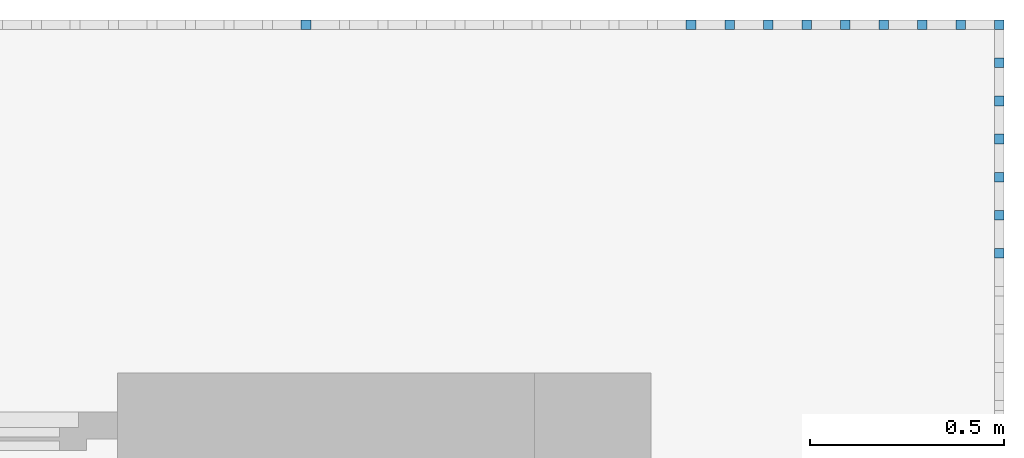
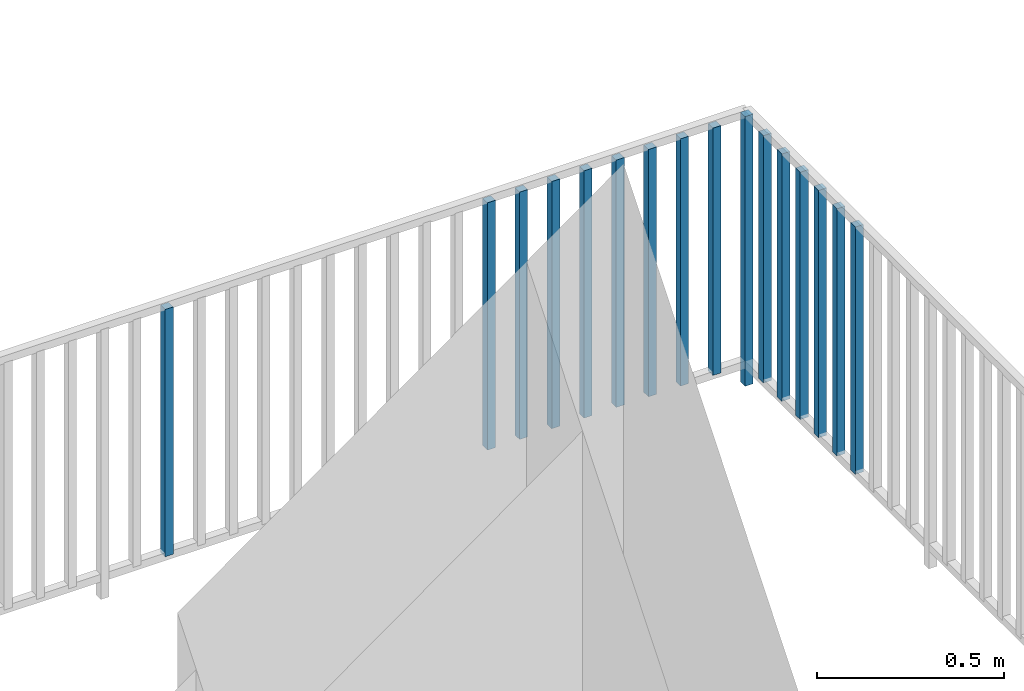
# One storey, part 48 of 48: 17 building element parts, 1 element without a shape of its own.
"""IFC4 building model written with IfcOpenShell, lengths in metres."""

import ifcopenshell
import ifcopenshell.guid

model = None  # the IFC model being written
_history = None  # IfcOwnerHistory: only IFC2X3 demands one
_inside = {}  # id of a spatial element -> (the spatial element, [elements in it])
_under = {}  # id of a project, library or spatial element -> (it, [spatial elements below it])
_declared = {}  # id of a project -> (the project, [libraries it declares])
_typed = {}  # id of a type object -> (the type object, [elements of that type])
_made_of = {}  # id of a material, layer set ... -> (it, [elements and type objects made of it])


def new_model(schema):
    """Start an empty IFC model of exactly this schema.

    Asked for "IFC4X3", IfcOpenShell would pick the latest addendum, in which some entities
    have other attributes; the version numbers below select the first issue.
    IFC2X3 requires an IfcOwnerHistory on every rooted entity: one is made here for all.
    """
    global model, _history
    if schema == "IFC4X3":
        model = ifcopenshell.file(schema_version=(4, 3, 0, 0))
    else:
        model = ifcopenshell.file(schema=schema)
    _inside.clear()
    _under.clear()
    _declared.clear()
    _typed.clear()
    _made_of.clear()
    _history = None
    if model.schema == "IFC2X3":
        org = make("IfcOrganization", Name="unknown")
        user = make(
            "IfcPersonAndOrganization",
            ThePerson=make("IfcPerson", FamilyName="unknown"),
            TheOrganization=org,
        )
        app = make(
            "IfcApplication",
            ApplicationDeveloper=org,
            Version="unknown",
            ApplicationFullName="unknown",
            ApplicationIdentifier="unknown",
        )
        _history = make(
            "IfcOwnerHistory",
            OwningUser=user,
            OwningApplication=app,
            ChangeAction="ADDED",
            CreationDate=0,
        )
    return model


def make(cls, **values):
    """One entity of the class cls with the attributes given. An attribute that is None is left unset."""
    return model.create_entity(
        cls, **{name: value for name, value in values.items() if value is not None}
    )


def entity(cls, *values):
    """Any entity or typed value of the class cls, its attributes in the order of the schema. None: left unset."""
    e = model.create_entity(cls)
    for i, value in enumerate(values):
        if value is not None:
            e[i] = value
    return e


def rooted(cls, **values):
    """An entity with a GlobalId (a new one), such as an element, a storey or a relation."""
    return make(cls, GlobalId=ifcopenshell.guid.new(), OwnerHistory=_history, **values)


def si_unit(unit_type, name, prefix=None):
    """IfcSIUnit, for example si_unit("LENGTHUNIT", "METRE", prefix="MILLI")."""
    return make("IfcSIUnit", UnitType=unit_type, Prefix=prefix, Name=name)


def converted_unit(unit_type, name, factor, base, dimensions=None, offset=None):
    """IfcConversionBasedUnit, such as the inch: factor (a typed value) times the base unit."""
    return make(
        "IfcConversionBasedUnit"
        if offset is None
        else "IfcConversionBasedUnitWithOffset",
        ConversionOffset=offset,
        Dimensions=None
        if dimensions is None
        else entity("IfcDimensionalExponents", *dimensions),
        UnitType=unit_type,
        Name=name,
        ConversionFactor=make(
            "IfcMeasureWithUnit", ValueComponent=factor, UnitComponent=base
        ),
    )


def derived_unit(unit_type, elements):
    """IfcDerivedUnit: a product of units, each with its exponent."""
    return make(
        "IfcDerivedUnit",
        Elements=[
            make("IfcDerivedUnitElement", Unit=unit, Exponent=power)
            for unit, power in elements
        ],
        UnitType=unit_type,
    )


def assignment(units):
    """IfcUnitAssignment: the units of a project."""
    return None if units is None else make("IfcUnitAssignment", Units=units)


def point(xyz):
    """IfcCartesianPoint."""
    return None if xyz is None else make("IfcCartesianPoint", Coordinates=xyz)


def direction(xyz):
    """IfcDirection."""
    return None if xyz is None else make("IfcDirection", DirectionRatios=xyz)


def frame(location, z_axis=None, x_axis=None):
    """IfcAxis2Placement3D, a coordinate frame: its origin and axes. An axis left out is left unset."""
    return make(
        "IfcAxis2Placement3D",
        Location=point(location),
        Axis=direction(z_axis),
        RefDirection=direction(x_axis),
    )


def origin_with_axes():
    """The frame at (0, 0, 0) with the z axis (0, 0, 1) and the x axis (1, 0, 0) written out."""
    return frame((0.0, 0.0, 0.0), z_axis=(0.0, 0.0, 1.0), x_axis=(1.0, 0.0, 0.0))


def place(relative_to, where):
    """IfcLocalPlacement: puts the frame where relative to a parent placement (None: the world)."""
    return make(
        "IfcLocalPlacement", PlacementRelTo=relative_to, RelativePlacement=where
    )


def context(
    kind, dimensions, precision=None, world=None, true_north=None, identifier=None
):
    """IfcGeometricRepresentationContext, for example the 3D "Model" context."""
    return make(
        "IfcGeometricRepresentationContext",
        ContextIdentifier=identifier,
        ContextType=kind,
        CoordinateSpaceDimension=dimensions,
        Precision=precision,
        WorldCoordinateSystem=world,
        TrueNorth=true_north,
    )


def subcontext(parent, identifier, kind, view, scale=None):
    """IfcGeometricRepresentationSubContext, for example "Body" below "Model"."""
    return make(
        "IfcGeometricRepresentationSubContext",
        ContextIdentifier=identifier,
        ContextType=kind,
        ParentContext=parent,
        TargetScale=scale,
        TargetView=view,
    )


def project(units=None, contexts=None):
    """IfcProject with its units and contexts."""
    return rooted(
        "IfcProject",
        Name="project",
        RepresentationContexts=contexts,
        UnitsInContext=assignment(units),
    )


def spatial(cls, under=None, at=None, **own):
    """A site, building, storey or space (cls), placed at a placement, below another one or the project."""
    s = rooted(cls, ObjectPlacement=at, **own)
    if under is not None:
        _under.setdefault(under.id(), (under, []))[1].append(s)
    return s


def point_list(points):
    """IfcCartesianPointList2D or 3D."""
    cls = (
        "IfcCartesianPointList2D" if len(points[0]) == 2 else "IfcCartesianPointList3D"
    )
    return make(cls, CoordList=points)


def polygons(points, faces, closed=None, point_numbers=None):
    """IfcPolygonalFaceSet: a face is its outer loop, then its inner loops; points numbered from 1."""
    made = []
    for loops in faces:
        if len(loops) == 1:
            made.append(make("IfcIndexedPolygonalFace", CoordIndex=loops[0]))
        else:
            made.append(
                make(
                    "IfcIndexedPolygonalFaceWithVoids",
                    CoordIndex=loops[0],
                    InnerCoordIndices=loops[1:],
                )
            )
    return make(
        "IfcPolygonalFaceSet",
        Coordinates=point_list(points),
        Closed=closed,
        Faces=made,
        PnIndex=point_numbers,
    )


def shape(context_of_items, identifier, shape_type, items):
    """IfcShapeRepresentation: the items that make up one representation, for example the "Body"."""
    return make(
        "IfcShapeRepresentation",
        ContextOfItems=context_of_items,
        RepresentationIdentifier=identifier,
        RepresentationType=shape_type,
        Items=items,
    )


def material(Name=None, Category=None):
    """IfcMaterial."""
    return make("IfcMaterial", Name=Name, Category=Category)


def made_of(thing, what):
    """Note that an element or type object is made of a material, layer set ...; save() writes the relation."""
    if what is not None:
        _made_of.setdefault(what.id(), (what, []))[1].append(thing)
    return thing


def type_object(cls, material=None, **own):
    """A type object (cls), such as IfcWallType, which elements share."""
    return made_of(rooted(cls, **own), material)


def element(
    cls,
    number,
    at=None,
    inside=None,
    cuts=None,
    type_object=None,
    material=None,
    context=None,
    identifier="Body",
    shape_type=None,
    held_by="IfcProductDefinitionShape",
    body=None,
    shapes=None,
    **own,
):
    """One element of the class cls, such as IfcWall. Its Tag is "e" and its number.

    at: its placement. inside: the storey or other place that contains it. cuts: it is an
    opening in that element (IfcRelVoidsElement). A single representation is given by context,
    identifier, shape_type and body (its items); several are given by shapes. held_by: the class
    of the entity that holds the representations. save() writes the other relations.
    """
    e = rooted(cls, Tag="e%d" % number, ObjectPlacement=at, **own)
    if body is not None:
        shapes = [shape(context, identifier, shape_type, body)]
    if shapes is not None:
        e.Representation = make(held_by, Representations=shapes)
    if inside is not None:
        _inside.setdefault(inside.id(), (inside, []))[1].append(e)
    if cuts is not None:
        rooted(
            "IfcRelVoidsElement", RelatingBuildingElement=cuts, RelatedOpeningElement=e
        )
    if type_object is not None:
        _typed.setdefault(type_object.id(), (type_object, []))[1].append(e)
    return made_of(e, material)


def aggregate(whole, parts):
    """IfcRelAggregates: a whole, such as a stair, and the parts it consists of."""
    return rooted("IfcRelAggregates", RelatingObject=whole, RelatedObjects=parts)


def save(model, path):
    """Write the relations noted so far, then the file.

    IfcRelAggregates (storeys below a building ...), IfcRelContainedInSpatialStructure (elements
    in a storey), IfcRelDefinesByType, IfcRelAssociatesMaterial and IfcRelDeclares: one each for
    every whole, place, type object, material and project.
    """
    for whole, parts in _under.values():
        aggregate(whole, parts)
    for where, things in _inside.values():
        rooted(
            "IfcRelContainedInSpatialStructure",
            RelatedElements=things,
            RelatingStructure=where,
        )
    for kind, things in _typed.values():
        rooted("IfcRelDefinesByType", RelatedObjects=things, RelatingType=kind)
    for what, things in _made_of.values():
        rooted("IfcRelAssociatesMaterial", RelatedObjects=things, RelatingMaterial=what)
    for by, libraries in _declared.values():
        rooted("IfcRelDeclares", RelatingContext=by, RelatedDefinitions=libraries)
    model.write(path)


model = new_model("IFC4")

# Units and contexts
model_context = context("Model", 3, precision=1e-05, world=origin_with_axes(), true_north=direction((0.0, 1.0)))
body_context = subcontext(model_context, "Body", "Model", "MODEL_VIEW")
ifc_project = project(units=[si_unit("LENGTHUNIT", "METRE"), si_unit("AREAUNIT", "SQUARE_METRE"), si_unit("VOLUMEUNIT", "CUBIC_METRE"), converted_unit("PLANEANGLEUNIT", "DEGREE", entity("IfcPlaneAngleMeasure", 0.0174532925199), si_unit("PLANEANGLEUNIT", "RADIAN"), dimensions=[0, 0, 0, 0, 0, 0, 0]), converted_unit("TIMEUNIT", "Year", entity("IfcTimeMeasure", 31556926.0), si_unit("TIMEUNIT", "SECOND"), dimensions=[0, 0, 1, 0, 0, 0, 0]), si_unit("MASSUNIT", "GRAM", prefix="KILO"), si_unit("THERMODYNAMICTEMPERATUREUNIT", "DEGREE_CELSIUS"), si_unit("LUMINOUSINTENSITYUNIT", "LUMEN"), si_unit("ENERGYUNIT", "JOULE", prefix="MEGA"), derived_unit("THERMALCONDUCTANCEUNIT", [(si_unit("POWERUNIT", "WATT"), 1), (si_unit("LENGTHUNIT", "METRE"), -1), (si_unit("THERMODYNAMICTEMPERATUREUNIT", "KELVIN"), -1)]), derived_unit("SPECIFICHEATCAPACITYUNIT", [(si_unit("ENERGYUNIT", "JOULE"), 1), (si_unit("MASSUNIT", "GRAM", prefix="KILO"), -1), (si_unit("THERMODYNAMICTEMPERATUREUNIT", "KELVIN"), -1)]), derived_unit("MASSDENSITYUNIT", [(si_unit("MASSUNIT", "GRAM", prefix="KILO"), 1), (si_unit("VOLUMEUNIT", "CUBIC_METRE"), -1)])], contexts=[model_context])

# Site, building, storey
site_placement = place(None, origin_with_axes())
site = spatial("IfcSite", under=ifc_project, at=site_placement, CompositionType="ELEMENT")
building_placement = place(site_placement, origin_with_axes())
building = spatial("IfcBuilding", under=site, at=building_placement, CompositionType="ELEMENT")
storey_placement = place(building_placement, frame((0.0, 0.0, 3.4), z_axis=(0.0, 0.0, 1.0), x_axis=(1.0, 0.0, 0.0)))
storey = spatial("IfcBuildingStorey", under=building, at=storey_placement, Name="1. Geschoss", CompositionType="ELEMENT", Elevation=3.4)

# Railing, building element parts
railing_type = type_object("IfcRailingType", PredefinedType="NOTDEFINED")
railing_placement = place(storey_placement, frame((10.2378006196, 9.82118776896, 0.0), z_axis=(0.0, 0.0, 1.0), x_axis=(1.0, 0.0, 0.0)))
railing = element("IfcRailing", 1, at=railing_placement, inside=storey, type_object=railing_type, PredefinedType="NOTDEFINED")
ifc_material = material()
building_element_part_1_placement = place(railing_placement, origin_with_axes())
building_element_part_1 = element("IfcBuildingElementPart", 2, at=building_element_part_1_placement, material=ifc_material, PredefinedType="NOTDEFINED", context=body_context, shape_type="Tessellation", body=[
    polygons([(-0.0125, 0.0125, 0.0), (-0.0125, -0.0125, 0.0), (-0.0125, -0.0125, 0.88), (-0.0125, 0.0125, 0.88), (0.0125, 0.0125, 0.0), (0.0125, -0.0125, 0.0), (0.0125, -0.0125, 0.88), (0.0125, 0.0125, 0.88)], [[[1, 2, 3, 4]], [[1, 5, 6, 2]], [[2, 6, 7, 3]], [[4, 3, 7, 8]], [[5, 1, 4, 8]], [[6, 5, 8, 7]]], closed=True),
])
building_element_part_2_placement = place(railing_placement, origin_with_axes())
building_element_part_2 = element("IfcBuildingElementPart", 3, at=building_element_part_2_placement, material=ifc_material, PredefinedType="NOTDEFINED", context=body_context, shape_type="Tessellation", body=[
    polygons([(0.0125, 0.0125, 0.0), (-0.0125, 0.0125, 0.0), (-0.0125, 0.0125, 0.88), (0.0125, 0.0125, 0.88), (0.0125, -0.0125, 0.0), (-0.0125, -0.0125, 0.0), (-0.0125, -0.0125, 0.88), (0.0125, -0.0125, 0.88)], [[[1, 2, 3, 4]], [[1, 5, 6, 2]], [[2, 6, 7, 3]], [[4, 3, 7, 8]], [[5, 1, 4, 8]], [[6, 5, 8, 7]]], closed=True),
])
building_element_part_3_placement = place(railing_placement, origin_with_axes())
building_element_part_3 = element("IfcBuildingElementPart", 4, at=building_element_part_3_placement, material=ifc_material, PredefinedType="NOTDEFINED", context=body_context, shape_type="Tessellation", body=[
    polygons([(-0.11197826087, 0.0125, 0.07), (-0.11197826087, -0.0125, 0.07), (-0.11197826087, -0.0125, 0.8775), (-0.11197826087, 0.0125, 0.8775), (-0.0869782608696, 0.0125, 0.07), (-0.0869782608696, -0.0125, 0.07), (-0.0869782608696, -0.0125, 0.8775), (-0.0869782608696, 0.0125, 0.8775)], [[[1, 2, 3, 4]], [[1, 5, 6, 2]], [[2, 6, 7, 3]], [[4, 3, 7, 8]], [[5, 1, 4, 8]], [[6, 5, 8, 7]]], closed=True),
])
building_element_part_4_placement = place(railing_placement, origin_with_axes())
building_element_part_4 = element("IfcBuildingElementPart", 5, at=building_element_part_4_placement, material=ifc_material, PredefinedType="NOTDEFINED", context=body_context, shape_type="Tessellation", body=[
    polygons([(-0.211456521739, 0.0125, 0.07), (-0.211456521739, -0.0125, 0.07), (-0.211456521739, -0.0125, 0.8775), (-0.211456521739, 0.0125, 0.8775), (-0.186456521739, 0.0125, 0.07), (-0.186456521739, -0.0125, 0.07), (-0.186456521739, -0.0125, 0.8775), (-0.186456521739, 0.0125, 0.8775)], [[[1, 2, 3, 4]], [[1, 5, 6, 2]], [[2, 6, 7, 3]], [[4, 3, 7, 8]], [[5, 1, 4, 8]], [[6, 5, 8, 7]]], closed=True),
])
building_element_part_5_placement = place(railing_placement, origin_with_axes())
building_element_part_5 = element("IfcBuildingElementPart", 6, at=building_element_part_5_placement, material=ifc_material, PredefinedType="NOTDEFINED", context=body_context, shape_type="Tessellation", body=[
    polygons([(-0.310934782609, 0.0125, 0.07), (-0.310934782609, -0.0125, 0.07), (-0.310934782609, -0.0125, 0.8775), (-0.310934782609, 0.0125, 0.8775), (-0.285934782609, 0.0125, 0.07), (-0.285934782609, -0.0125, 0.07), (-0.285934782609, -0.0125, 0.8775), (-0.285934782609, 0.0125, 0.8775)], [[[1, 2, 3, 4]], [[1, 5, 6, 2]], [[2, 6, 7, 3]], [[4, 3, 7, 8]], [[5, 1, 4, 8]], [[6, 5, 8, 7]]], closed=True),
])
building_element_part_6_placement = place(railing_placement, origin_with_axes())
building_element_part_6 = element("IfcBuildingElementPart", 7, at=building_element_part_6_placement, material=ifc_material, PredefinedType="NOTDEFINED", context=body_context, shape_type="Tessellation", body=[
    polygons([(-0.410413043478, 0.0125, 0.07), (-0.410413043478, -0.0125, 0.07), (-0.410413043478, -0.0125, 0.8775), (-0.410413043478, 0.0125, 0.8775), (-0.385413043478, 0.0125, 0.07), (-0.385413043478, -0.0125, 0.07), (-0.385413043478, -0.0125, 0.8775), (-0.385413043478, 0.0125, 0.8775)], [[[1, 2, 3, 4]], [[1, 5, 6, 2]], [[2, 6, 7, 3]], [[4, 3, 7, 8]], [[5, 1, 4, 8]], [[6, 5, 8, 7]]], closed=True),
])
building_element_part_7_placement = place(railing_placement, origin_with_axes())
building_element_part_7 = element("IfcBuildingElementPart", 8, at=building_element_part_7_placement, material=ifc_material, PredefinedType="NOTDEFINED", context=body_context, shape_type="Tessellation", body=[
    polygons([(-0.509891304348, 0.0125, 0.07), (-0.509891304348, -0.0125, 0.07), (-0.509891304348, -0.0125, 0.8775), (-0.509891304348, 0.0125, 0.8775), (-0.484891304348, 0.0125, 0.07), (-0.484891304348, -0.0125, 0.07), (-0.484891304348, -0.0125, 0.8775), (-0.484891304348, 0.0125, 0.8775)], [[[1, 2, 3, 4]], [[1, 5, 6, 2]], [[2, 6, 7, 3]], [[4, 3, 7, 8]], [[5, 1, 4, 8]], [[6, 5, 8, 7]]], closed=True),
])
building_element_part_8_placement = place(railing_placement, origin_with_axes())
building_element_part_8 = element("IfcBuildingElementPart", 9, at=building_element_part_8_placement, material=ifc_material, PredefinedType="NOTDEFINED", context=body_context, shape_type="Tessellation", body=[
    polygons([(-0.609369565217, 0.0125, 0.07), (-0.609369565217, -0.0125, 0.07), (-0.609369565217, -0.0125, 0.8775), (-0.609369565217, 0.0125, 0.8775), (-0.584369565217, 0.0125, 0.07), (-0.584369565217, -0.0125, 0.07), (-0.584369565217, -0.0125, 0.8775), (-0.584369565217, 0.0125, 0.8775)], [[[1, 2, 3, 4]], [[1, 5, 6, 2]], [[2, 6, 7, 3]], [[4, 3, 7, 8]], [[5, 1, 4, 8]], [[6, 5, 8, 7]]], closed=True),
])
building_element_part_9_placement = place(railing_placement, origin_with_axes())
building_element_part_9 = element("IfcBuildingElementPart", 10, at=building_element_part_9_placement, material=ifc_material, PredefinedType="NOTDEFINED", context=body_context, shape_type="Tessellation", body=[
    polygons([(-0.708847826087, 0.0125, 0.07), (-0.708847826087, -0.0125, 0.07), (-0.708847826087, -0.0125, 0.8775), (-0.708847826087, 0.0125, 0.8775), (-0.683847826087, 0.0125, 0.07), (-0.683847826087, -0.0125, 0.07), (-0.683847826087, -0.0125, 0.8775), (-0.683847826087, 0.0125, 0.8775)], [[[1, 2, 3, 4]], [[1, 5, 6, 2]], [[2, 6, 7, 3]], [[4, 3, 7, 8]], [[5, 1, 4, 8]], [[6, 5, 8, 7]]], closed=True),
])
building_element_part_10_placement = place(railing_placement, origin_with_axes())
building_element_part_10 = element("IfcBuildingElementPart", 11, at=building_element_part_10_placement, material=ifc_material, PredefinedType="NOTDEFINED", context=body_context, shape_type="Tessellation", body=[
    polygons([(-0.808326086957, 0.0125, 0.07), (-0.808326086957, -0.0125, 0.07), (-0.808326086957, -0.0125, 0.8775), (-0.808326086957, 0.0125, 0.8775), (-0.783326086957, 0.0125, 0.07), (-0.783326086957, -0.0125, 0.07), (-0.783326086957, -0.0125, 0.8775), (-0.783326086957, 0.0125, 0.8775)], [[[1, 2, 3, 4]], [[1, 5, 6, 2]], [[2, 6, 7, 3]], [[4, 3, 7, 8]], [[5, 1, 4, 8]], [[6, 5, 8, 7]]], closed=True),
])
building_element_part_11_placement = place(railing_placement, origin_with_axes())
building_element_part_11 = element("IfcBuildingElementPart", 12, at=building_element_part_11_placement, material=ifc_material, PredefinedType="NOTDEFINED", context=body_context, shape_type="Tessellation", body=[
    polygons([(-1.80310869565, 0.0125, 0.07), (-1.80310869565, -0.0125, 0.07), (-1.80310869565, -0.0125, 0.8775), (-1.80310869565, 0.0125, 0.8775), (-1.77810869565, 0.0125, 0.07), (-1.77810869565, -0.0125, 0.07), (-1.77810869565, -0.0125, 0.8775), (-1.77810869565, 0.0125, 0.8775)], [[[1, 2, 3, 4]], [[1, 5, 6, 2]], [[2, 6, 7, 3]], [[4, 3, 7, 8]], [[5, 1, 4, 8]], [[6, 5, 8, 7]]], closed=True),
])
building_element_part_12_placement = place(railing_placement, origin_with_axes())
building_element_part_12 = element("IfcBuildingElementPart", 13, at=building_element_part_12_placement, material=ifc_material, PredefinedType="NOTDEFINED", context=body_context, shape_type="Tessellation", body=[
    polygons([(0.0125, -0.5775, 0.07), (-0.0125, -0.5775, 0.07), (-0.0125, -0.5775, 0.8775), (0.0125, -0.5775, 0.8775), (0.0125, -0.6025, 0.07), (-0.0125, -0.6025, 0.07), (-0.0125, -0.6025, 0.8775), (0.0125, -0.6025, 0.8775)], [[[1, 2, 3, 4]], [[1, 5, 6, 2]], [[2, 6, 7, 3]], [[4, 3, 7, 8]], [[5, 1, 4, 8]], [[6, 5, 8, 7]]], closed=True),
])
building_element_part_13_placement = place(railing_placement, origin_with_axes())
building_element_part_13 = element("IfcBuildingElementPart", 14, at=building_element_part_13_placement, material=ifc_material, PredefinedType="NOTDEFINED", context=body_context, shape_type="Tessellation", body=[
    polygons([(0.0125, -0.479166666667, 0.07), (-0.0125, -0.479166666667, 0.07), (-0.0125, -0.479166666667, 0.8775), (0.0125, -0.479166666667, 0.8775), (0.0125, -0.504166666667, 0.07), (-0.0125, -0.504166666667, 0.07), (-0.0125, -0.504166666667, 0.8775), (0.0125, -0.504166666667, 0.8775)], [[[1, 2, 3, 4]], [[1, 5, 6, 2]], [[2, 6, 7, 3]], [[4, 3, 7, 8]], [[5, 1, 4, 8]], [[6, 5, 8, 7]]], closed=True),
])
building_element_part_14_placement = place(railing_placement, origin_with_axes())
building_element_part_14 = element("IfcBuildingElementPart", 15, at=building_element_part_14_placement, material=ifc_material, PredefinedType="NOTDEFINED", context=body_context, shape_type="Tessellation", body=[
    polygons([(0.0125, -0.380833333333, 0.07), (-0.0125, -0.380833333333, 0.07), (-0.0125, -0.380833333333, 0.8775), (0.0125, -0.380833333333, 0.8775), (0.0125, -0.405833333333, 0.07), (-0.0125, -0.405833333333, 0.07), (-0.0125, -0.405833333333, 0.8775), (0.0125, -0.405833333333, 0.8775)], [[[1, 2, 3, 4]], [[1, 5, 6, 2]], [[2, 6, 7, 3]], [[4, 3, 7, 8]], [[5, 1, 4, 8]], [[6, 5, 8, 7]]], closed=True),
])
building_element_part_15_placement = place(railing_placement, origin_with_axes())
building_element_part_15 = element("IfcBuildingElementPart", 16, at=building_element_part_15_placement, material=ifc_material, PredefinedType="NOTDEFINED", context=body_context, shape_type="Tessellation", body=[
    polygons([(0.0125, -0.2825, 0.07), (-0.0125, -0.2825, 0.07), (-0.0125, -0.2825, 0.8775), (0.0125, -0.2825, 0.8775), (0.0125, -0.3075, 0.07), (-0.0125, -0.3075, 0.07), (-0.0125, -0.3075, 0.8775), (0.0125, -0.3075, 0.8775)], [[[1, 2, 3, 4]], [[1, 5, 6, 2]], [[2, 6, 7, 3]], [[4, 3, 7, 8]], [[5, 1, 4, 8]], [[6, 5, 8, 7]]], closed=True),
])
building_element_part_16_placement = place(railing_placement, origin_with_axes())
building_element_part_16 = element("IfcBuildingElementPart", 17, at=building_element_part_16_placement, material=ifc_material, PredefinedType="NOTDEFINED", context=body_context, shape_type="Tessellation", body=[
    polygons([(0.0125, -0.184166666667, 0.07), (-0.0125, -0.184166666667, 0.07), (-0.0125, -0.184166666667, 0.8775), (0.0125, -0.184166666667, 0.8775), (0.0125, -0.209166666667, 0.07), (-0.0125, -0.209166666667, 0.07), (-0.0125, -0.209166666667, 0.8775), (0.0125, -0.209166666667, 0.8775)], [[[1, 2, 3, 4]], [[1, 5, 6, 2]], [[2, 6, 7, 3]], [[4, 3, 7, 8]], [[5, 1, 4, 8]], [[6, 5, 8, 7]]], closed=True),
])
building_element_part_17_placement = place(railing_placement, origin_with_axes())
building_element_part_17 = element("IfcBuildingElementPart", 18, at=building_element_part_17_placement, material=ifc_material, PredefinedType="NOTDEFINED", context=body_context, shape_type="Tessellation", body=[
    polygons([(0.0125, -0.0858333333333, 0.07), (-0.0125, -0.0858333333333, 0.07), (-0.0125, -0.0858333333333, 0.8775), (0.0125, -0.0858333333333, 0.8775), (0.0125, -0.110833333333, 0.07), (-0.0125, -0.110833333333, 0.07), (-0.0125, -0.110833333333, 0.8775), (0.0125, -0.110833333333, 0.8775)], [[[1, 2, 3, 4]], [[1, 5, 6, 2]], [[2, 6, 7, 3]], [[4, 3, 7, 8]], [[5, 1, 4, 8]], [[6, 5, 8, 7]]], closed=True),
])
aggregate(railing, [building_element_part_1, building_element_part_2, building_element_part_3, building_element_part_4, building_element_part_5, building_element_part_6, building_element_part_7, building_element_part_8, building_element_part_9, building_element_part_10, building_element_part_11, building_element_part_12, building_element_part_13, building_element_part_14, building_element_part_15, building_element_part_16, building_element_part_17])

save(model, "model.ifc")
